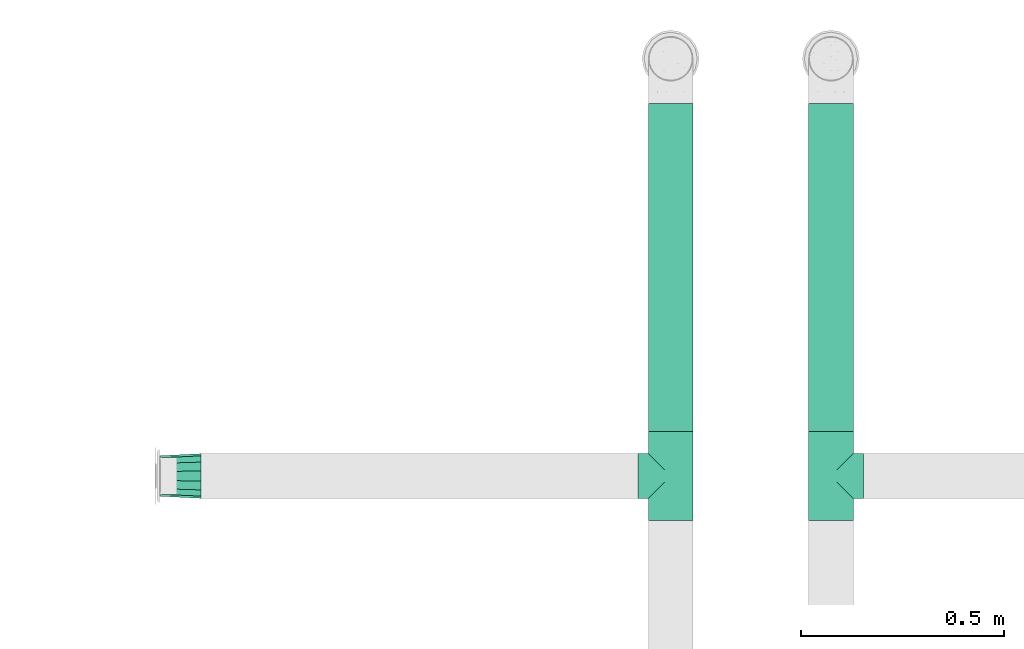
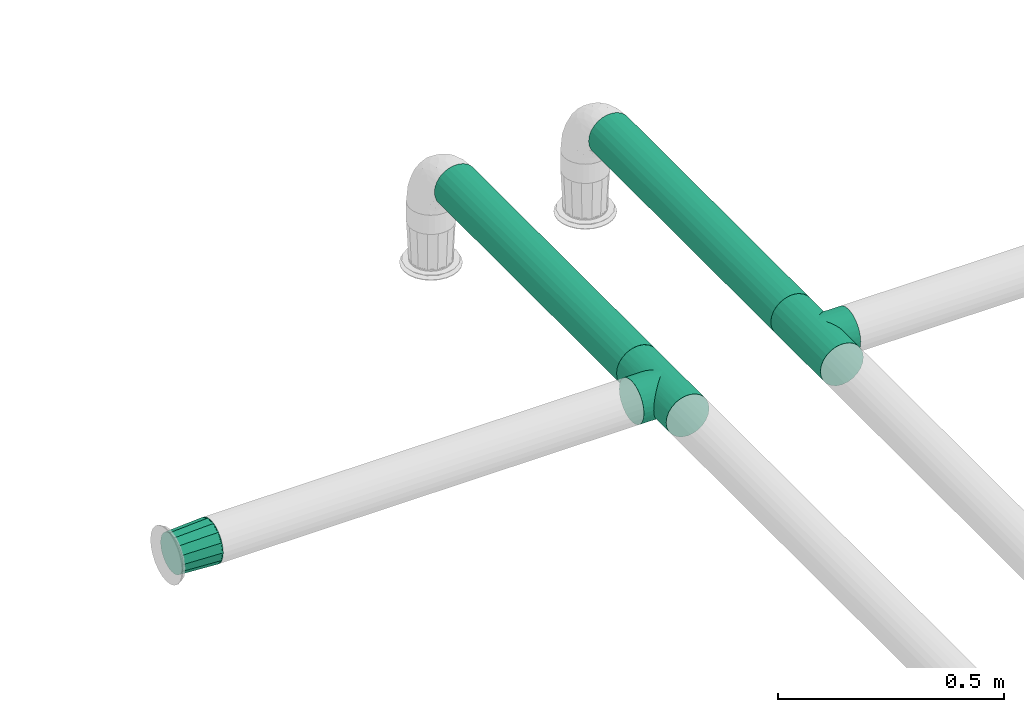
# One storey, part 18 of 115: 3 flow fittings, 2 flow segments.
"""IFC2X3 building model written with IfcOpenShell, lengths in millimetres."""

from ifc_helpers import new_model, entity, si_unit, converted_unit, derived_unit, direction, frame, origin_with_axes, origin_2d_with_axis, place, context, subcontext, project, spatial, hollow_circle, extrude, open_shell, surface_model, source, transform, mapped, material, layer, layer_set, layer_usage, type_object, element, save


model = new_model("IFC2X3")

# Units and contexts
model_context = context("Model", 3, precision=1e-05, world=origin_with_axes(), true_north=direction((0.0, 1.0)))
body_context = subcontext(model_context, "Body", "Model", "MODEL_VIEW")
ifc_project = project(units=[si_unit("AREAUNIT", "SQUARE_METRE"), si_unit("VOLUMEUNIT", "CUBIC_METRE", prefix="DECI"), si_unit("TIMEUNIT", "SECOND"), si_unit("THERMODYNAMICTEMPERATUREUNIT", "DEGREE_CELSIUS"), si_unit("PRESSUREUNIT", "PASCAL"), si_unit("MASSUNIT", "GRAM", prefix="KILO"), si_unit("LENGTHUNIT", "METRE", prefix="MILLI"), si_unit("POWERUNIT", "WATT"), si_unit("ELECTRICCURRENTUNIT", "AMPERE"), si_unit("ELECTRICVOLTAGEUNIT", "VOLT"), derived_unit("VOLUMETRICFLOWRATEUNIT", [(si_unit("VOLUMEUNIT", "CUBIC_METRE", prefix="DECI"), 1), (si_unit("TIMEUNIT", "SECOND"), -1)]), derived_unit("LINEARVELOCITYUNIT", [(si_unit("LENGTHUNIT", "METRE"), 1), (si_unit("TIMEUNIT", "SECOND"), -1)]), derived_unit("MASSDENSITYUNIT", [(si_unit("MASSUNIT", "GRAM", prefix="KILO"), 1), (si_unit("VOLUMEUNIT", "CUBIC_METRE"), -1)]), converted_unit("PLANEANGLEUNIT", "DEGREE", entity("IfcRatioMeasure", 0.01745), si_unit("PLANEANGLEUNIT", "RADIAN"), dimensions=[0, 0, 0, 0, 0, 0, 0])], contexts=[model_context])

# Site, building, storey
site_placement = place(None, origin_with_axes())
site = spatial("IfcSite", under=ifc_project, at=site_placement, CompositionType="ELEMENT")
building_placement = place(site_placement, origin_with_axes())
building = spatial("IfcBuilding", under=site, at=building_placement, Name="mc-building", CompositionType="ELEMENT")
storey_placement = place(building_placement, frame((0.0, 0.0, 2950.0), z_axis=(0.0, 0.0, 1.0), x_axis=(1.0, 0.0, 0.0)))
storey = spatial("IfcBuildingStorey", under=building, at=storey_placement, Name="2. Korrus", CompositionType="ELEMENT", Elevation=2950.0)

# Flow fittings
duct_fitting_type_1 = type_object("IfcDuctFittingType", PredefinedType="JUNCTION")
shared_shape_1 = source(origin_with_axes(), body_context, "Body", "SurfaceModel", [
    surface_model("IfcShellBasedSurfaceModel", [(0.0, -80.0, -55.0), (14.23505, -80.0, -53.12592), (-14.23505, -80.0, -53.12592), (-53.12592, -80.0, 14.23505), (-27.5, -80.0, -47.63139), (-47.63139, -80.0, -27.5), (-38.89087, -80.0, -38.89087), (55.0, -80.0, 0.0), (53.12592, -80.0, 14.23505), (38.89087, -80.0, -38.89087), (27.5, -80.0, -47.63139), (53.12592, -80.0, -14.23505), (47.63139, -80.0, -27.5), (-53.12592, -80.0, -14.23505), (-47.63139, -80.0, 27.5), (-38.89087, -80.0, 38.89087), (14.23505, -80.0, 53.12592), (-27.5, -80.0, 47.63139), (-14.23505, -80.0, 53.12592), (47.63139, -80.0, 27.5), (38.89087, -80.0, 38.89087), (27.5, -80.0, 47.63139), (0.0, -80.0, 55.0), (-55.0, -80.0, 0.0), (0.0, 0.0, 55.0), (-7.4066, -7.4066, 54.49901), (-14.74521, -14.74521, 52.98659), (-21.93978, -21.93978, 50.43457), (-28.89905, -28.89905, 46.79578), (-35.50357, -35.50357, 42.00591), (-41.58668, -41.58668, 35.99373), (-46.92319, -46.92319, 28.69171), (-51.19777, -51.19777, 20.0945), (-50.37866, -80.0, 20.86752), (-54.01174, -54.01174, 10.37938), (-55.0, -55.0, 0.0), (-54.06296, -80.0, 7.11752), (-54.01174, -54.01174, -10.37938), (-51.19777, -51.19777, -20.0945), (-54.06296, -80.0, -7.11752), (-46.92319, -46.92319, -28.69171), (-41.58668, -41.58668, -35.99373), (-50.37866, -80.0, -20.86752), (-35.50357, -35.50357, -42.00591), (-21.93978, -21.93978, -50.43457), (-14.74521, -14.74521, -52.98659), (-7.4066, -7.4066, -54.49901), (0.0, 0.0, -55.0), (-28.89905, -28.89905, -46.79578), (7.4066, -7.4066, -54.49901), (14.74521, -14.74521, -52.98659), (21.93978, -21.93978, -50.43457), (28.89905, -28.89905, -46.79578), (35.50357, -35.50357, -42.00591), (41.58668, -41.58668, -35.99373), (46.92319, -46.92319, -28.69171), (51.19777, -51.19777, -20.0945), (50.37866, -80.0, -20.86752), (54.01174, -54.01174, -10.37938), (55.0, -55.0, 0.0), (54.06296, -80.0, -7.11752), (54.01174, -54.01174, 10.37938), (51.19777, -51.19777, 20.0945), (54.06296, -80.0, 7.11752), (46.92319, -46.92319, 28.69171), (41.58668, -41.58668, 35.99373), (50.37866, -80.0, 20.86752), (35.50357, -35.50357, 42.00591), (21.93978, -21.93978, 50.43457), (14.74521, -14.74521, 52.98659), (7.4066, -7.4066, 54.49901), (28.89905, -28.89905, 46.79578), (-110.0, 0.0, -55.0), (-110.0, -14.23505, -53.12592), (-110.0, 14.23505, -53.12592), (-110.0, 53.12592, 14.23505), (-110.0, 27.5, -47.63139), (-110.0, 47.63139, -27.5), (-110.0, 38.89087, -38.89087), (-110.0, -55.0, 0.0), (-110.0, -53.12592, 14.23505), (-110.0, -38.89087, -38.89087), (-110.0, -27.5, -47.63139), (-110.0, -53.12592, -14.23505), (-110.0, -47.63139, -27.5), (-110.0, 53.12592, -14.23505), (-110.0, 47.63139, 27.5), (-110.0, 38.89087, 38.89087), (-110.0, -14.23505, 53.12592), (-110.0, 27.5, 47.63139), (-110.0, 14.23505, 53.12592), (-110.0, -47.63139, 27.5), (-110.0, -38.89087, 38.89087), (-110.0, -27.5, 47.63139), (-110.0, 0.0, 55.0), (-110.0, 55.0, 0.0), (110.0, 55.0, 0.0), (110.0, 0.0, -55.0), (110.0, 14.23505, -53.12592), (110.0, 27.5, -47.63139), (110.0, 38.89087, -38.89087), (110.0, 47.63139, -27.5), (110.0, -38.89087, -38.89087), (110.0, -53.12592, 14.23505), (110.0, -27.5, -47.63139), (110.0, -14.23505, -53.12592), (110.0, -47.63139, -27.5), (110.0, -53.12592, -14.23505), (110.0, -55.0, 0.0), (110.0, 53.12592, -14.23505), (110.0, 53.12592, 14.23505), (110.0, 47.63139, 27.5), (110.0, 38.89087, 38.89087), (110.0, 0.0, 55.0), (110.0, 27.5, 47.63139), (110.0, 14.23505, 53.12592), (110.0, -47.63139, 27.5), (110.0, -38.89087, 38.89087), (110.0, -27.5, 47.63139), (110.0, -14.23505, 53.12592)], [open_shell([[[0, 1, 2]], [[2, 3, 4]], [[5, 6, 3]], [[6, 4, 3]], [[2, 7, 8]], [[9, 7, 10]], [[1, 10, 7]], [[11, 7, 12]], [[9, 12, 7]], [[7, 2, 1]], [[5, 3, 13]], [[2, 14, 3]], [[2, 15, 14]], [[2, 16, 17]], [[17, 15, 2]], [[16, 18, 17]], [[2, 8, 19]], [[2, 19, 20]], [[2, 20, 21]], [[16, 2, 21]], [[16, 22, 18]], [[23, 13, 3]], [[24, 25, 22]], [[26, 27, 18]], [[25, 26, 18]], [[22, 25, 18]], [[17, 28, 29]], [[17, 18, 27]], [[17, 29, 15]], [[28, 17, 27]], [[30, 31, 14]], [[32, 3, 33]], [[32, 34, 3]], [[35, 36, 34]], [[31, 32, 14]], [[15, 30, 14]], [[34, 36, 3]], [[33, 14, 32]], [[36, 35, 23]], [[30, 15, 29]], [[37, 38, 13]], [[37, 13, 39]], [[40, 41, 5]], [[38, 5, 42]], [[38, 40, 5]], [[37, 39, 35]], [[35, 39, 23]], [[13, 38, 42]], [[41, 6, 5]], [[41, 43, 6]], [[44, 45, 2]], [[46, 47, 0]], [[45, 46, 2]], [[43, 48, 4]], [[44, 4, 48]], [[44, 2, 4]], [[46, 0, 2]], [[43, 4, 6]], [[47, 49, 0]], [[50, 51, 1]], [[49, 50, 1]], [[0, 49, 1]], [[10, 52, 53]], [[10, 1, 51]], [[10, 53, 9]], [[52, 10, 51]], [[54, 55, 12]], [[56, 11, 57]], [[56, 58, 11]], [[59, 60, 58]], [[55, 56, 12]], [[9, 54, 12]], [[58, 60, 11]], [[57, 12, 56]], [[60, 59, 7]], [[54, 9, 53]], [[61, 62, 8]], [[61, 8, 63]], [[64, 65, 19]], [[62, 19, 66]], [[62, 64, 19]], [[61, 63, 59]], [[7, 59, 63]], [[62, 66, 8]], [[65, 20, 19]], [[65, 67, 20]], [[68, 69, 16]], [[70, 24, 22]], [[69, 70, 16]], [[67, 71, 21]], [[68, 21, 71]], [[68, 16, 21]], [[70, 22, 16]], [[67, 21, 20]], [[72, 73, 74]], [[74, 75, 76]], [[77, 78, 75]], [[76, 75, 78]], [[74, 79, 80]], [[81, 79, 82]], [[73, 82, 79]], [[83, 79, 84]], [[81, 84, 79]], [[79, 74, 73]], [[77, 75, 85]], [[74, 86, 75]], [[74, 87, 86]], [[74, 88, 89]], [[89, 87, 74]], [[88, 90, 89]], [[74, 91, 92]], [[91, 74, 80]], [[92, 93, 74]], [[74, 93, 88]], [[88, 94, 90]], [[95, 85, 75]], [[96, 97, 98]], [[99, 96, 98]], [[96, 100, 101]], [[100, 96, 99]], [[102, 97, 103]], [[97, 102, 104]], [[104, 105, 97]], [[102, 103, 106]], [[106, 103, 107]], [[108, 107, 103]], [[109, 96, 101]], [[110, 111, 97]], [[97, 111, 112]], [[113, 97, 114]], [[97, 112, 114]], [[113, 114, 115]], [[116, 103, 97]], [[117, 116, 97]], [[118, 117, 97]], [[119, 118, 97]], [[119, 97, 113]], [[96, 110, 97]], [[24, 113, 115]], [[89, 115, 114]], [[94, 24, 90]], [[90, 24, 115]], [[115, 89, 90]], [[114, 87, 89]], [[86, 112, 111]], [[75, 111, 110]], [[95, 110, 96]], [[87, 112, 86]], [[86, 111, 75]], [[110, 95, 75]], [[112, 87, 114]], [[85, 96, 109]], [[77, 109, 101]], [[95, 96, 85]], [[85, 109, 77]], [[101, 78, 77]], [[101, 100, 78]], [[76, 100, 99]], [[74, 99, 98]], [[47, 98, 97]], [[76, 99, 74]], [[47, 72, 74]], [[98, 47, 74]], [[100, 76, 78]], [[47, 46, 72]], [[45, 44, 73]], [[46, 45, 73]], [[72, 46, 73]], [[82, 48, 43]], [[82, 73, 44]], [[82, 43, 81]], [[48, 82, 44]], [[41, 40, 84]], [[38, 37, 83]], [[40, 38, 84]], [[81, 41, 84]], [[37, 79, 83]], [[83, 84, 38]], [[79, 37, 35]], [[41, 81, 43]], [[49, 97, 105]], [[105, 104, 51]], [[53, 104, 102]], [[53, 52, 104]], [[49, 47, 97]], [[51, 50, 105]], [[52, 51, 104]], [[49, 105, 50]], [[54, 102, 106]], [[56, 106, 107]], [[58, 107, 108]], [[55, 54, 106]], [[58, 56, 107]], [[59, 58, 108]], [[55, 106, 56]], [[102, 54, 53]], [[34, 32, 80]], [[31, 30, 91]], [[32, 31, 91]], [[35, 34, 79]], [[80, 79, 34]], [[32, 91, 80]], [[30, 92, 91]], [[30, 29, 92]], [[27, 26, 88]], [[25, 24, 94]], [[26, 25, 88]], [[29, 28, 93]], [[27, 93, 28]], [[27, 88, 93]], [[25, 94, 88]], [[29, 93, 92]], [[61, 108, 103]], [[62, 103, 116]], [[65, 116, 117]], [[61, 59, 108]], [[64, 62, 116]], [[65, 64, 116]], [[61, 103, 62]], [[117, 67, 65]], [[71, 67, 118]], [[118, 67, 117]], [[68, 118, 119]], [[70, 119, 113]], [[68, 71, 118]], [[70, 69, 119]], [[24, 70, 113]], [[68, 119, 69]]])]),
])
flow_fitting_1_placement = place(storey_placement, frame((8987.56202, 3666.26111, 2465.0), z_axis=(0.0, 0.0, 1.0), x_axis=(0.0, 1.0, 0.0)))
element("IfcFlowFitting", 1, at=flow_fitting_1_placement, inside=storey, type_object=duct_fitting_type_1, context=body_context, shape_type="MappedRepresentation", body=[
    mapped(shared_shape_1, transform((0.0, 0.0, 0.0), scale=1.0)),
])
shared_shape_2 = source(origin_with_axes(), body_context, "Body", "SurfaceModel", [
    surface_model("IfcShellBasedSurfaceModel", [(-110.0, -38.89087, -38.89087), (-110.0, -55.0, 0.0), (-110.0, -27.5, -47.63139), (-110.0, -53.12592, -14.23505), (-110.0, -47.63139, -27.5), (-110.0, 47.63139, -27.5), (-110.0, 53.12592, 14.23505), (-110.0, 53.12592, -14.23505), (-110.0, 55.0, 0.0), (110.0, 38.89087, -38.89087), (110.0, 55.0, 0.0), (110.0, 27.5, -47.63139), (110.0, -38.89087, -38.89087), (110.0, -53.12592, 14.23505), (110.0, -47.63139, -27.5), (110.0, -55.0, 0.0), (110.0, -53.12592, -14.23505), (110.0, 53.12592, -14.23505), (110.0, 47.63139, -27.5), (-110.0, 38.89087, -38.89087), (-110.0, -14.23505, -53.12592), (-110.0, 0.0, -55.0), (-110.0, 27.5, -47.63139), (-110.0, 14.23505, -53.12592), (-110.0, -53.12592, 14.23505), (-110.0, -47.63139, 27.5), (-110.0, -38.89087, 38.89087), (-110.0, 14.23505, 53.12592), (-110.0, 27.5, 47.63139), (-55.0, 80.0, 0.0), (0.0, 80.0, -55.0), (-14.23505, 80.0, -53.12592), (-27.5, 80.0, -47.63139), (-38.89087, 80.0, -38.89087), (-47.63139, 80.0, -27.5), (38.89087, 80.0, -38.89087), (53.12592, 80.0, 14.23505), (27.5, 80.0, -47.63139), (14.23505, 80.0, -53.12592), (47.63139, 80.0, -27.5), (53.12592, 80.0, -14.23505), (55.0, 80.0, 0.0), (-53.12592, 80.0, -14.23505), (-53.12592, 80.0, 14.23505), (-47.63139, 80.0, 27.5), (-38.89087, 80.0, 38.89087), (0.0, 80.0, 55.0), (-27.5, 80.0, 47.63139), (-14.23505, 80.0, 53.12592), (47.63139, 80.0, 27.5), (38.89087, 80.0, 38.89087), (27.5, 80.0, 47.63139), (14.23505, 80.0, 53.12592), (-7.4066, 7.4066, 54.49901), (0.0, 0.0, 55.0), (-21.93978, 21.93978, 50.43457), (-14.74521, 14.74521, 52.98659), (-35.50357, 35.50357, 42.00591), (-28.89905, 28.89905, 46.79578), (-46.92319, 46.92319, 28.69171), (-41.58668, 41.58668, 35.99373), (-54.01174, 54.01174, 10.37938), (-54.06296, 80.0, 7.11752), (-55.0, 55.0, 0.0), (-51.19777, 51.19777, 20.0945), (-50.37866, 80.0, 20.86752), (-51.19777, 51.19777, -20.0945), (-54.01174, 54.01174, -10.37938), (-50.37866, 80.0, -20.86752), (-41.58668, 41.58668, -35.99373), (-46.92319, 46.92319, -28.69171), (-54.06296, 80.0, -7.11752), (-35.50357, 35.50357, -42.00591), (-14.74521, 14.74521, -52.98659), (-21.93978, 21.93978, -50.43457), (0.0, 0.0, -55.0), (-7.4066, 7.4066, -54.49901), (-28.89905, 28.89905, -46.79578), (7.4066, 7.4066, -54.49901), (21.93978, 21.93978, -50.43457), (14.74521, 14.74521, -52.98659), (35.50357, 35.50357, -42.00591), (28.89905, 28.89905, -46.79578), (46.92319, 46.92319, -28.69171), (41.58668, 41.58668, -35.99373), (54.01174, 54.01174, -10.37938), (54.06296, 80.0, -7.11752), (55.0, 55.0, 0.0), (51.19777, 51.19777, -20.0945), (50.37866, 80.0, -20.86752), (51.19777, 51.19777, 20.0945), (54.01174, 54.01174, 10.37938), (50.37866, 80.0, 20.86752), (41.58668, 41.58668, 35.99373), (46.92319, 46.92319, 28.69171), (54.06296, 80.0, 7.11752), (35.50357, 35.50357, 42.00591), (14.74521, 14.74521, 52.98659), (21.93978, 21.93978, 50.43457), (7.4066, 7.4066, 54.49901), (28.89905, 28.89905, 46.79578), (-110.0, -27.5, 47.63139), (-110.0, 0.0, 55.0), (-110.0, -14.23505, 53.12592), (-110.0, 47.63139, 27.5), (-110.0, 38.89087, 38.89087), (110.0, 0.0, -55.0), (110.0, 14.23505, -53.12592), (110.0, -14.23505, -53.12592), (110.0, -27.5, -47.63139), (110.0, 53.12592, 14.23505), (110.0, -47.63139, 27.5), (110.0, -38.89087, 38.89087), (110.0, 14.23505, 53.12592), (110.0, -27.5, 47.63139), (110.0, -14.23505, 53.12592), (110.0, 47.63139, 27.5), (110.0, 38.89087, 38.89087), (110.0, 27.5, 47.63139), (110.0, 0.0, 55.0)], [open_shell([[[0, 1, 2]], [[3, 1, 4]], [[5, 6, 7]], [[8, 7, 6]], [[9, 10, 11]], [[12, 13, 14]], [[15, 16, 13]], [[17, 10, 18]], [[19, 6, 5]], [[2, 1, 20]], [[19, 21, 6]], [[21, 19, 22]], [[22, 23, 21]], [[24, 25, 21]], [[21, 25, 26]], [[27, 28, 21]], [[29, 30, 31]], [[32, 29, 31]], [[29, 33, 34]], [[29, 32, 33]], [[35, 30, 36]], [[30, 35, 37]], [[37, 38, 30]], [[35, 36, 39]], [[39, 36, 40]], [[41, 40, 36]], [[42, 29, 34]], [[43, 44, 30]], [[30, 44, 45]], [[46, 30, 47]], [[30, 45, 47]], [[46, 47, 48]], [[49, 36, 30]], [[50, 49, 30]], [[51, 50, 30]], [[52, 51, 30]], [[52, 30, 46]], [[29, 43, 30]], [[46, 53, 54]], [[48, 55, 56]], [[48, 56, 53]], [[48, 53, 46]], [[57, 58, 47]], [[55, 48, 47]], [[45, 57, 47]], [[55, 47, 58]], [[44, 59, 60]], [[61, 62, 63]], [[43, 61, 64]], [[65, 43, 64]], [[44, 64, 59]], [[44, 60, 45]], [[43, 62, 61]], [[64, 44, 65]], [[29, 63, 62]], [[57, 45, 60]], [[42, 66, 67]], [[68, 34, 66]], [[34, 69, 70]], [[71, 42, 67]], [[34, 70, 66]], [[63, 71, 67]], [[29, 71, 63]], [[68, 66, 42]], [[34, 33, 69]], [[33, 72, 69]], [[31, 73, 74]], [[30, 75, 76]], [[31, 76, 73]], [[32, 77, 72]], [[77, 32, 74]], [[32, 31, 74]], [[31, 30, 76]], [[33, 32, 72]], [[30, 78, 75]], [[38, 79, 80]], [[38, 80, 78]], [[38, 78, 30]], [[81, 82, 37]], [[79, 38, 37]], [[35, 81, 37]], [[79, 37, 82]], [[39, 83, 84]], [[85, 86, 87]], [[40, 85, 88]], [[89, 40, 88]], [[39, 88, 83]], [[39, 84, 35]], [[40, 86, 85]], [[88, 39, 89]], [[41, 87, 86]], [[81, 35, 84]], [[36, 90, 91]], [[92, 49, 90]], [[49, 93, 94]], [[95, 36, 91]], [[49, 94, 90]], [[87, 95, 91]], [[95, 87, 41]], [[36, 92, 90]], [[49, 50, 93]], [[50, 96, 93]], [[52, 97, 98]], [[46, 54, 99]], [[52, 99, 97]], [[51, 100, 96]], [[100, 51, 98]], [[51, 52, 98]], [[52, 46, 99]], [[50, 51, 96]], [[1, 21, 20]], [[1, 0, 4]], [[101, 102, 26]], [[102, 21, 26]], [[102, 101, 103]], [[104, 6, 21]], [[105, 104, 21]], [[105, 21, 28]], [[21, 102, 27]], [[1, 24, 21]], [[106, 107, 108]], [[108, 13, 109]], [[109, 13, 12]], [[108, 10, 110]], [[107, 11, 10]], [[9, 18, 10]], [[10, 108, 107]], [[16, 14, 13]], [[108, 111, 13]], [[108, 112, 111]], [[108, 113, 114]], [[114, 112, 108]], [[113, 115, 114]], [[108, 110, 116]], [[108, 116, 117]], [[108, 117, 118]], [[113, 108, 118]], [[113, 119, 115]], [[115, 119, 54]], [[114, 115, 101]], [[103, 54, 102]], [[115, 54, 103]], [[103, 101, 115]], [[101, 26, 114]], [[111, 112, 25]], [[13, 111, 24]], [[15, 13, 1]], [[25, 112, 26]], [[24, 111, 25]], [[24, 1, 13]], [[114, 26, 112]], [[16, 15, 3]], [[14, 16, 4]], [[3, 15, 1]], [[4, 16, 3]], [[4, 0, 14]], [[0, 12, 14]], [[109, 12, 2]], [[108, 109, 20]], [[106, 108, 75]], [[20, 109, 2]], [[20, 21, 75]], [[20, 75, 108]], [[0, 2, 12]], [[21, 76, 75]], [[23, 74, 73]], [[23, 73, 76]], [[23, 76, 21]], [[72, 77, 22]], [[74, 23, 22]], [[19, 72, 22]], [[74, 22, 77]], [[5, 70, 69]], [[7, 67, 66]], [[5, 66, 70]], [[5, 69, 19]], [[7, 8, 67]], [[66, 5, 7]], [[63, 67, 8]], [[72, 19, 69]], [[107, 106, 78]], [[79, 11, 107]], [[9, 11, 81]], [[11, 82, 81]], [[106, 75, 78]], [[107, 80, 79]], [[11, 79, 82]], [[80, 107, 78]], [[18, 9, 84]], [[17, 18, 88]], [[10, 17, 85]], [[18, 84, 83]], [[17, 88, 85]], [[10, 85, 87]], [[88, 18, 83]], [[81, 84, 9]], [[110, 10, 91]], [[116, 110, 90]], [[117, 116, 93]], [[10, 87, 91]], [[116, 90, 94]], [[116, 94, 93]], [[90, 110, 91]], [[93, 96, 117]], [[118, 96, 100]], [[117, 96, 118]], [[113, 118, 98]], [[119, 113, 99]], [[118, 100, 98]], [[113, 97, 99]], [[119, 99, 54]], [[97, 113, 98]], [[6, 64, 61]], [[104, 60, 59]], [[104, 59, 64]], [[8, 61, 63]], [[61, 8, 6]], [[6, 104, 64]], [[104, 105, 60]], [[105, 57, 60]], [[27, 56, 55]], [[102, 54, 53]], [[27, 53, 56]], [[28, 58, 57]], [[58, 28, 55]], [[28, 27, 55]], [[27, 102, 53]], [[105, 28, 57]]])]),
])
flow_fitting_2_placement = place(storey_placement, frame((8592.78509, 3666.26111, 2465.0), z_axis=(0.0, 0.0, 1.0), x_axis=(0.0, 1.0, 0.0)))
element("IfcFlowFitting", 2, at=flow_fitting_2_placement, inside=storey, type_object=duct_fitting_type_1, context=body_context, shape_type="MappedRepresentation", body=[
    mapped(shared_shape_2, transform((0.0, 0.0, 0.0), scale=1.0)),
])
duct_fitting_type_2 = type_object("IfcDuctFittingType", PredefinedType="TRANSITION")
shared_shape_3 = source(origin_with_axes(), body_context, "Body", "SurfaceModel", [
    surface_model("IfcShellBasedSurfaceModel", [(100.0, -55.0, 0.0), (100.0, -12.23865, 53.62104), (100.0, -34.29194, 43.00073), (100.0, 49.55329, 23.86361), (100.0, 34.29194, 43.00073), (100.0, 49.55329, -23.86361), (0.0, -45.04844, -21.69419), (0.0, -50.0, 0.0), (0.0, -45.04844, 21.69419), (0.0, 31.17449, 39.09157), (0.0, 45.04844, 21.69419), (0.0, 50.0, 0.0), (98.0, 47.63139, 27.5), (98.0, 0.0, 55.0), (98.0, 38.89087, 38.89087), (98.0, -38.89087, 38.89087), (98.0, -47.63139, 27.5), (100.0, 12.23865, 53.62104), (100.0, -49.55329, 23.86361), (100.0, 55.0, 0.0), (100.0, 12.23865, -53.62104), (100.0, 34.29194, -43.00073), (100.0, -49.55329, -23.86361), (100.0, -34.29194, -43.00073), (100.0, -12.23865, -53.62104), (0.0, -31.17449, 39.09157), (0.0, -11.12605, 48.7464), (0.0, 11.12605, 48.7464), (0.0, -31.17449, -39.09157), (0.0, 11.12605, -48.7464), (0.0, -11.12605, -48.7464), (0.0, 45.04844, -21.69419), (0.0, 31.17449, -39.09157), (0.0, 47.52422, -10.84709), (0.0, 38.11147, -30.39288), (100.0, 41.92261, -33.43217), (100.0, -41.92261, -33.43217), (0.0, -38.11147, -30.39288), (100.0, 23.2653, -48.31088), (0.0, 21.15027, -43.91899), (100.0, 52.32388, -11.72483), (0.0, 0.0, -48.7464), (100.0, 0.0, -53.62104), (0.0, -21.15027, -43.91899), (100.0, -23.2653, -48.31088), (0.0, -47.52422, -10.84709), (100.0, -52.32388, -11.72483), (0.0, -47.52422, 10.84709), (0.0, -38.11147, 30.39288), (100.0, -41.92261, 33.43217), (100.0, 41.92261, 33.43217), (0.0, 38.11147, 30.39288), (100.0, -23.2653, 48.31088), (0.0, -21.15027, 43.91899), (100.0, -52.32388, 11.72483), (0.0, 0.0, 48.7464), (100.0, 0.0, 53.62104), (0.0, 21.15027, 43.91899), (100.0, 23.2653, 48.31088), (0.0, 47.52422, 10.84709), (100.0, 52.32388, 11.72483), (100.0, -14.23505, -53.12592), (100.0, 0.0, -55.0), (100.0, -27.5, -47.63139), (100.0, 27.5, -47.63139), (100.0, -38.89087, -38.89087), (100.0, -53.12592, -14.23505), (100.0, -47.63139, -27.5), (100.0, -47.63139, 27.5), (100.0, 14.23505, -53.12592), (100.0, 38.89087, -38.89087), (100.0, 47.63139, -27.5), (100.0, 47.63139, 27.5), (100.0, 53.12592, -14.23505), (100.0, -53.12592, 14.23505), (100.0, -38.89087, 38.89087), (100.0, -27.5, 47.63139), (100.0, 0.0, 55.0), (100.0, -14.23505, 53.12592), (100.0, 53.12592, 14.23505), (100.0, 38.89087, 38.89087), (100.0, 27.5, 47.63139), (100.0, 14.23505, 53.12592), (98.0, -27.5, 47.63139), (98.0, -14.23505, 53.12592), (98.0, -53.12592, -14.23505), (98.0, 14.23505, 53.12592), (98.0, 27.5, 47.63139), (98.0, 53.12592, 14.23505), (98.0, 55.0, 0.0), (98.0, -47.63139, -27.5), (98.0, -53.12592, 14.23505), (98.0, 27.5, -47.63139), (98.0, -27.5, -47.63139), (98.0, -38.89087, -38.89087), (98.0, 0.0, -55.0), (98.0, -14.23505, -53.12592), (98.0, 38.89087, -38.89087), (98.0, 47.63139, -27.5), (98.0, 53.12592, -14.23505), (98.0, 14.23505, -53.12592), (98.0, -55.0, 0.0), (0.0, 0.0, 50.0), (0.0, 35.35534, 35.35534), (0.0, -12.94095, 48.29629), (0.0, -25.0, 43.30127), (0.0, -35.35534, 35.35534), (0.0, -48.29629, 12.94095), (0.0, -43.30127, 25.0), (0.0, 25.0, 43.30127), (0.0, 12.94095, 48.29629), (0.0, 43.30127, 25.0), (0.0, 48.29629, 12.94095), (0.0, 25.0, -43.30127), (0.0, 48.29629, -12.94095), (0.0, -48.29629, -12.94095), (0.0, -43.30127, -25.0), (0.0, -12.94095, -48.29629), (0.0, -25.0, -43.30127), (0.0, -35.35534, -35.35534), (0.0, 43.30127, -25.0), (0.0, 35.35534, -35.35534), (0.0, 12.94095, -48.29629), (0.0, 0.0, -50.0), (2.0, -35.35534, -35.35534), (2.0, -25.0, -43.30127), (2.0, -12.94095, -48.29629), (2.0, -43.30127, -25.0), (2.0, 0.0, -50.0), (2.0, -48.29629, -12.94095), (2.0, -50.0, 0.0), (2.0, 12.94095, -48.29629), (2.0, 25.0, -43.30127), (2.0, 43.30127, -25.0), (2.0, 48.29629, -12.94095), (2.0, 35.35534, -35.35534), (2.0, -48.29629, 12.94095), (2.0, -35.35534, 35.35534), (2.0, -43.30127, 25.0), (2.0, 35.35534, 35.35534), (2.0, -12.94095, 48.29629), (2.0, -25.0, 43.30127), (2.0, 0.0, 50.0), (2.0, 43.30127, 25.0), (2.0, 48.29629, 12.94095), (2.0, 50.0, 0.0), (2.0, 25.0, 43.30127), (2.0, 12.94095, 48.29629)], [open_shell([[[0, 1, 2]], [[3, 4, 5]], [[6, 7, 8]], [[9, 10, 11]], [[12, 13, 14]], [[15, 13, 16]], [[0, 4, 17]], [[2, 18, 0]], [[1, 0, 17]], [[3, 5, 19]], [[20, 21, 5]], [[22, 20, 5]], [[22, 5, 0]], [[22, 23, 24]], [[22, 24, 20]], [[4, 0, 5]], [[8, 25, 6]], [[6, 25, 26]], [[6, 26, 27]], [[11, 27, 9]], [[28, 6, 29]], [[30, 28, 29]], [[31, 6, 11]], [[31, 32, 29]], [[31, 29, 6]], [[27, 11, 6]], [[31, 33, 5]], [[34, 35, 32]], [[36, 22, 6]], [[36, 37, 23]], [[38, 29, 39]], [[33, 40, 5]], [[33, 11, 40]], [[19, 40, 11]], [[32, 21, 39]], [[32, 35, 21]], [[34, 31, 35]], [[30, 41, 42]], [[28, 43, 44]], [[42, 41, 20]], [[7, 45, 46]], [[38, 39, 21]], [[46, 0, 7]], [[6, 37, 36]], [[38, 20, 29]], [[43, 30, 24]], [[42, 24, 30]], [[28, 23, 37]], [[6, 22, 45]], [[35, 31, 5]], [[44, 43, 24]], [[20, 41, 29]], [[46, 45, 22]], [[44, 23, 28]], [[8, 47, 18]], [[48, 49, 25]], [[50, 3, 10]], [[50, 51, 4]], [[52, 26, 53]], [[47, 54, 18]], [[47, 7, 54]], [[0, 54, 7]], [[25, 2, 53]], [[25, 49, 2]], [[48, 8, 49]], [[27, 55, 56]], [[9, 57, 58]], [[56, 55, 1]], [[11, 59, 60]], [[52, 53, 2]], [[60, 19, 11]], [[10, 51, 50]], [[52, 1, 26]], [[57, 27, 17]], [[56, 17, 27]], [[9, 4, 51]], [[10, 3, 59]], [[49, 8, 18]], [[58, 57, 17]], [[1, 55, 26]], [[60, 59, 3]], [[58, 4, 9]], [[61, 62, 63]], [[63, 64, 65]], [[66, 67, 68]], [[65, 64, 67]], [[67, 64, 68]], [[69, 64, 62]], [[64, 63, 62]], [[70, 71, 64]], [[72, 64, 71]], [[71, 73, 19]], [[74, 0, 66]], [[72, 68, 64]], [[75, 68, 76]], [[77, 78, 76]], [[72, 76, 68]], [[76, 72, 77]], [[79, 72, 19]], [[19, 72, 71]], [[80, 81, 77]], [[77, 72, 80]], [[82, 77, 81]], [[74, 66, 68]], [[83, 84, 13]], [[15, 83, 13]], [[12, 16, 13]], [[16, 12, 85]], [[86, 87, 13]], [[87, 14, 13]], [[88, 89, 12]], [[89, 90, 12]], [[91, 16, 85]], [[90, 85, 12]], [[89, 92, 90]], [[93, 94, 95]], [[95, 94, 90]], [[96, 93, 95]], [[97, 92, 98]], [[98, 89, 99]], [[100, 95, 92]], [[92, 89, 98]], [[90, 92, 95]], [[101, 91, 85]], [[89, 73, 99]], [[99, 71, 98]], [[92, 97, 64]], [[70, 97, 98]], [[100, 92, 69]], [[73, 71, 99]], [[89, 19, 73]], [[92, 64, 69]], [[64, 97, 70]], [[98, 71, 70]], [[100, 69, 62]], [[62, 95, 100]], [[95, 61, 96]], [[96, 63, 93]], [[90, 94, 67]], [[65, 94, 93]], [[85, 90, 66]], [[63, 65, 93]], [[96, 61, 63]], [[85, 66, 0]], [[66, 90, 67]], [[94, 65, 67]], [[85, 0, 101]], [[62, 61, 95]], [[101, 74, 91]], [[91, 68, 16]], [[83, 15, 76]], [[75, 15, 16]], [[84, 83, 78]], [[74, 68, 91]], [[101, 0, 74]], [[83, 76, 78]], [[76, 15, 75]], [[16, 68, 75]], [[84, 78, 77]], [[77, 13, 84]], [[13, 82, 86]], [[86, 81, 87]], [[12, 14, 72]], [[80, 14, 87]], [[88, 12, 79]], [[81, 80, 87]], [[86, 82, 81]], [[88, 79, 19]], [[79, 12, 72]], [[14, 80, 72]], [[88, 19, 89]], [[77, 82, 13]], [[102, 103, 104]], [[105, 104, 106]], [[107, 108, 106]], [[103, 106, 104]], [[106, 103, 107]], [[109, 103, 110]], [[103, 102, 110]], [[111, 112, 103]], [[113, 103, 112]], [[112, 11, 114]], [[107, 103, 113]], [[113, 115, 107]], [[116, 115, 117]], [[117, 118, 119]], [[116, 117, 119]], [[117, 115, 113]], [[120, 121, 114]], [[113, 114, 121]], [[113, 122, 117]], [[113, 112, 114]], [[117, 122, 123]], [[7, 107, 115]], [[124, 125, 126]], [[127, 124, 126]], [[128, 129, 126]], [[127, 126, 129]], [[130, 129, 128]], [[131, 132, 128]], [[132, 130, 128]], [[133, 134, 135]], [[132, 135, 134]], [[132, 134, 130]], [[134, 136, 130]], [[137, 138, 136]], [[137, 136, 139]], [[140, 137, 139]], [[141, 137, 140]], [[142, 140, 139]], [[143, 139, 144]], [[144, 134, 145]], [[146, 147, 139]], [[139, 136, 144]], [[139, 147, 142]], [[136, 134, 144]], [[11, 134, 114]], [[114, 133, 120]], [[113, 121, 132]], [[135, 121, 120]], [[122, 113, 131]], [[134, 133, 114]], [[11, 145, 134]], [[113, 132, 131]], [[132, 121, 135]], [[120, 133, 135]], [[122, 131, 128]], [[128, 123, 122]], [[123, 126, 117]], [[117, 125, 118]], [[116, 119, 127]], [[124, 119, 118]], [[115, 116, 129]], [[125, 124, 118]], [[117, 126, 125]], [[115, 129, 130]], [[129, 116, 127]], [[119, 124, 127]], [[115, 130, 7]], [[128, 126, 123]], [[7, 136, 107]], [[107, 138, 108]], [[105, 106, 141]], [[137, 106, 108]], [[104, 105, 140]], [[136, 138, 107]], [[7, 130, 136]], [[105, 141, 140]], [[141, 106, 137]], [[108, 138, 137]], [[104, 140, 142]], [[142, 102, 104]], [[102, 147, 110]], [[110, 146, 109]], [[111, 103, 143]], [[139, 103, 109]], [[112, 111, 144]], [[146, 139, 109]], [[110, 147, 146]], [[112, 144, 145]], [[144, 111, 143]], [[103, 139, 143]], [[112, 145, 11]], [[142, 147, 102]]])]),
])
flow_fitting_3_placement = place(storey_placement, frame((7336.46806, 3666.26111, 2465.0), z_axis=(0.0, 0.0, 1.0), x_axis=(1.0, 0.0, 0.0)))
element("IfcFlowFitting", 3, at=flow_fitting_3_placement, inside=storey, type_object=duct_fitting_type_2, context=body_context, shape_type="MappedRepresentation", body=[
    mapped(shared_shape_3, transform((0.0, 0.0, 0.0), scale=1.0)),
])

# Flow segments
ifc_material = material(Name="FZ1")
ifc_layer = layer(ifc_material, 0.0)
ifc_layer_set = layer_set([ifc_layer], Name="FZ1")
ifc_layer_usage = layer_usage(ifc_layer_set, "AXIS1", "POSITIVE", 0.0)
duct_segment_type = type_object("IfcDuctSegmentType", PredefinedType="RIGIDSEGMENT")
shared_shape_4 = source(origin_with_axes(), body_context, "Body", "SweptSolid", [
    extrude(hollow_circle(Radius=55.0, WallThickness=2.0, at=origin_2d_with_axis()), frame((0.0, 0.0, 0.0), z_axis=(1.0, 0.0, 0.0), x_axis=(0.0, 1.0, 0.0)), (0.0, 0.0, 1.0), 807.6),
])
for number, where, z_axis, x_axis in (
    (4, (8987.56202, 3776.26111, 2465.0), (0.0, 0.0, 1.0), (0.0, 1.0, 0.0)),
    (5, (8592.78509, 3776.26111, 2465.0), (0.0, 0.0, 1.0), (0.0, 1.0, 0.0)),
):
    element("IfcFlowSegment", number, at=place(storey_placement, frame(where, z_axis=z_axis, x_axis=x_axis)), inside=storey, type_object=duct_segment_type, material=ifc_layer_usage, context=body_context, shape_type="MappedRepresentation", body=[
        mapped(shared_shape_4, transform((0.0, 0.0, 0.0), scale=1.0)),
    ])

save(model, "model.ifc")
